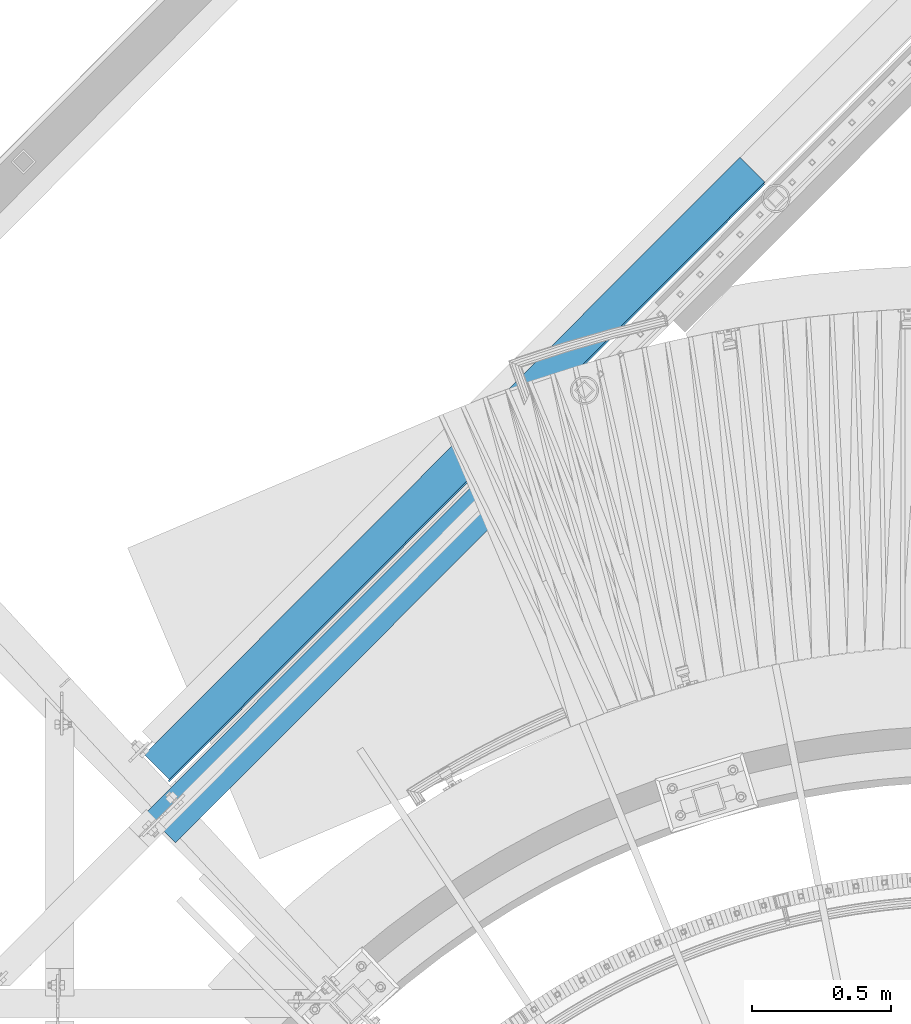
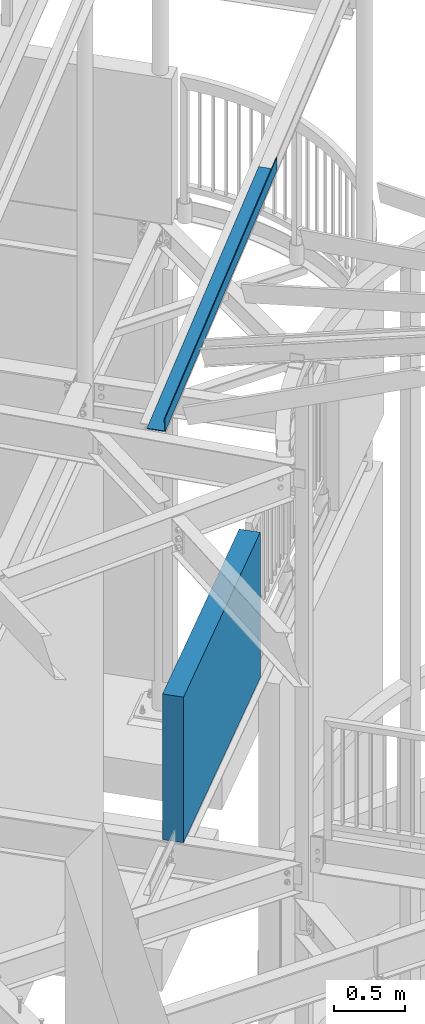
# One storey, part 368 of 975: 2 beams.
"""IFC2X3 building model written with IfcOpenShell, lengths in millimetres."""

from ifc_helpers import new_model, si_unit, frame, origin_with_axes, place, context, subcontext, project, spatial, faceted_brep, material, type_object, element, save


model = new_model("IFC2X3")

# Units and contexts
model_context = context("Model", 3, precision=1e-05, world=origin_with_axes())
body_context = subcontext(model_context, "Body", "Model", "MODEL_VIEW")
ifc_project = project(units=[si_unit("LENGTHUNIT", "METRE", prefix="MILLI"), si_unit("AREAUNIT", "SQUARE_METRE"), si_unit("VOLUMEUNIT", "CUBIC_METRE"), si_unit("MASSUNIT", "GRAM", prefix="KILO"), si_unit("TIMEUNIT", "SECOND"), si_unit("PLANEANGLEUNIT", "RADIAN"), si_unit("SOLIDANGLEUNIT", "STERADIAN"), si_unit("THERMODYNAMICTEMPERATUREUNIT", "DEGREE_CELSIUS"), si_unit("LUMINOUSINTENSITYUNIT", "LUMEN")], contexts=[model_context])

# Site, building, storey
site_placement = place(None, origin_with_axes())
site = spatial("IfcSite", under=ifc_project, at=site_placement, CompositionType="ELEMENT")
building_placement = place(site_placement, origin_with_axes())
building = spatial("IfcBuilding", under=site, at=building_placement, Name="Undefined", CompositionType="ELEMENT")
storey_placement = place(building_placement, origin_with_axes())
storey = spatial("IfcBuildingStorey", under=building, at=storey_placement, Name="Undefined", CompositionType="ELEMENT", Elevation=0.0)

# Beams
ifc_material_1 = material(Name="STEEL/A36")
beam_type_1 = type_object("IfcBeamType", PredefinedType="NOTDEFINED")
beam_1_placement = place(storey_placement, frame((32821.4287574756, 7795.67361680359, 7410.58211795563), z_axis=(-0.704820138136317, -0.706998290775193, -0.0581548769963319), x_axis=(0.708196855160895, -0.706015024160385, 1.72999999439031e-07)))
element("IfcBeam", 1, at=beam_1_placement, inside=storey, type_object=beam_type_1, material=ifc_material_1, Name="DECK_EDGE", context=body_context, shape_type="Brep", body=[
    faceted_brep([(-1.44573277793825e-08, -3.17500000027667, -1523.99999999641), (7.79618858359754e-09, -3.17499999972461, 1523.99999999641), (1.44573277793825e-08, 3.17500000027576, 1523.99999999641), (-7.79255060479045e-09, 3.17499999972188, -1523.9999999964), (127.239425638934, 3.1749998666337, 1523.99999999608), (127.239425598666, 3.17499986608073, -1523.99999999673), (133.589575834543, -3.17500014058805, -1523.99999999675), (133.589575874805, -3.17500014003508, 1523.99999999606), (127.236871653407, 111.124854602654, 1523.99999999558), (127.236871631256, 111.124854584082, -1523.99999999724), (133.586871651612, 111.12500483676, 1523.99999999557), (133.586871629464, 111.125004818188, -1523.99999999725)], [[[0, 1, 2, 3]], [[3, 2, 4, 5]], [[1, 0, 6, 7]], [[5, 4, 8, 9]], [[4, 2, 1, 7, 10, 8]], [[7, 6, 11, 10]], [[6, 0, 3, 5, 9, 11]], [[10, 11, 9, 8]]]),
])
ifc_material_2 = material(Name="CONCRETE/5000")
beam_type_2 = type_object("IfcBeamType", PredefinedType="NOTDEFINED")
beam_2_placement = place(storey_placement, frame((33277.1831938522, 7927.5607211233, 4559.3), z_axis=(0.0, 0.0, 1.0), x_axis=(-0.706311124041064, -0.707901544041153, 0.0)))
element("IfcBeam", 2, at=beam_2_placement, inside=storey, type_object=beam_type_2, material=ifc_material_2, Name="LOW WALL", context=body_context, shape_type="Brep", body=[
    faceted_brep([(1.0550138540566e-10, 76.1999999999316, -622.3), (1.0550138540566e-10, 76.1999999999316, 622.3), (2082.80000000209, 76.1999999983855, 622.3), (2082.80000000209, 76.1999999983855, -622.3), (-1.01863406598568e-10, -76.1999999999243, 622.3), (2082.80000000188, -76.2000000014668, 622.3), (-1.01863406598568e-10, -76.1999999999243, -622.3), (2082.80000000188, -76.2000000014668, -622.3)], [[[0, 1, 2, 3]], [[1, 4, 5, 2]], [[4, 6, 7, 5]], [[6, 0, 3, 7]], [[5, 7, 3, 2]], [[6, 4, 1, 0]]]),
])

save(model, "model.ifc")
